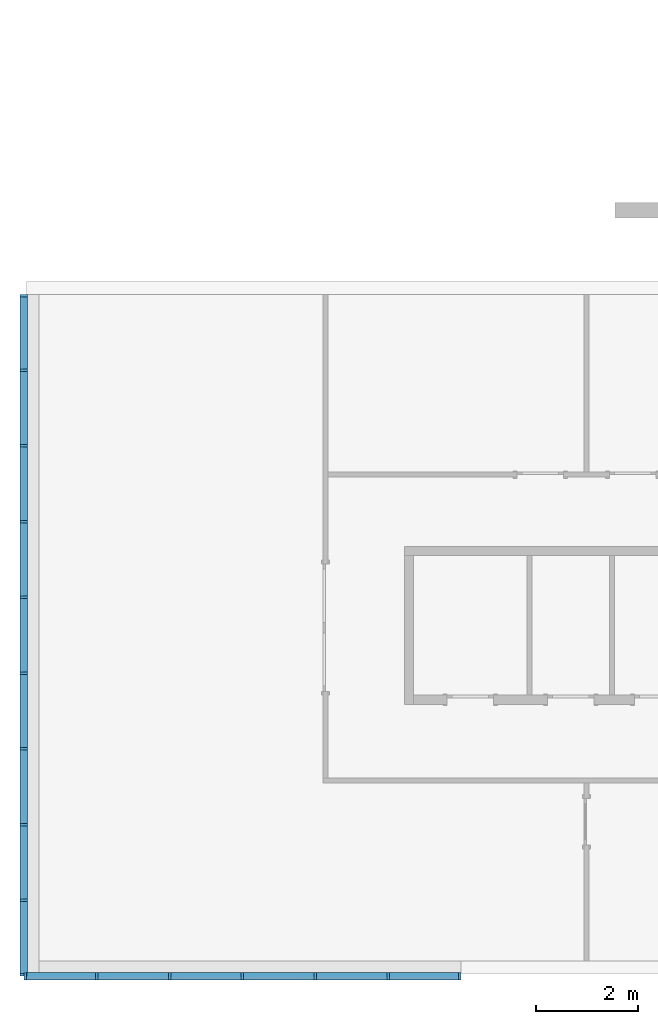
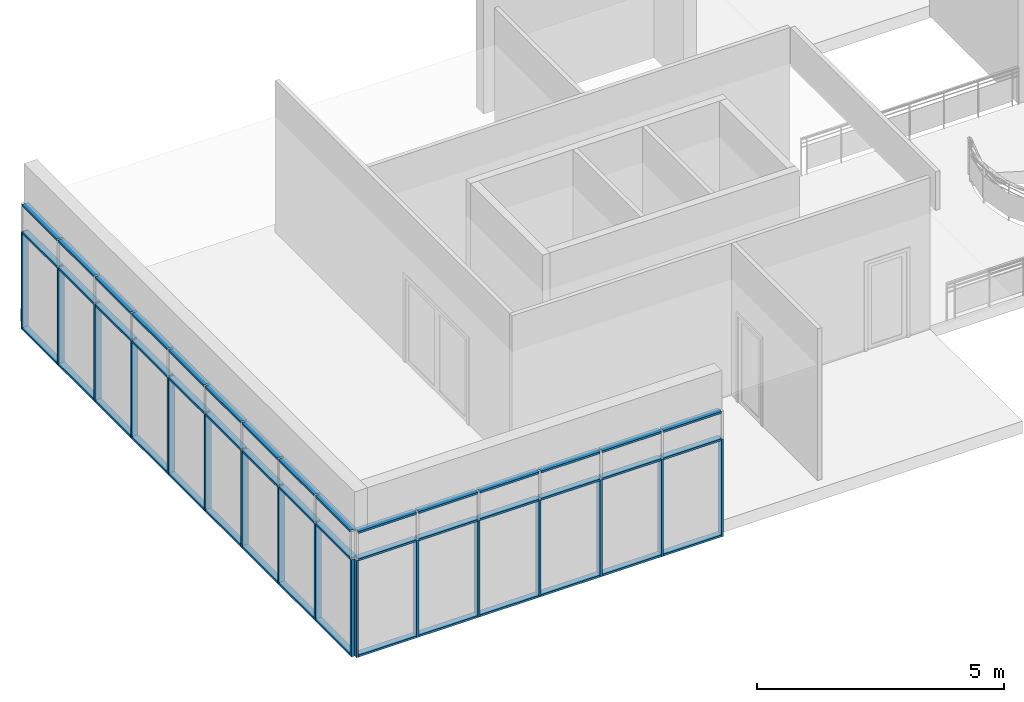
# One storey, part 1 of 11: 62 members, 2 elements without a shape of their own.
"""IFC2X3 building model written with IfcOpenShell, lengths in millimetres."""

from ifc_helpers import new_model, entity, si_unit, converted_unit, direction, frame, frame_2d, origin, origin_2d_with_axis, place, context, subcontext, project, spatial, rectangle, extrude, element, aggregate, save


model = new_model("IFC2X3")

# Units and contexts
model_context = context("Model", 3, precision=1e-06, world=origin(), true_north=direction((2.0, 6.12303176911189e-17, 1.0)))
context_of_model = context(None, 3, precision=1e-06, world=origin(), true_north=direction((2.0, 6.12303176911189e-17, 1.0)))
body_context = subcontext(model_context, "Body", "Model", "MODEL_VIEW")
ifc_project = project(units=[si_unit("LENGTHUNIT", "METRE", prefix="MILLI"), si_unit("AREAUNIT", "SQUARE_METRE", prefix="MILLI"), si_unit("VOLUMEUNIT", "CUBIC_METRE", prefix="MILLI"), converted_unit("PLANEANGLEUNIT", "DEGREE", entity("IfcRatioMeasure", 0.0174532925199433), si_unit("PLANEANGLEUNIT", "RADIAN"), dimensions=[0, 0, 0, 0, 0, 0, 0]), si_unit("TIMEUNIT", "SECOND")], contexts=[model_context, context_of_model])

# Site, building, storey
site_placement = place(None, origin())
site = spatial("IfcSite", under=ifc_project, at=site_placement, CompositionType="ELEMENT")
building_placement = place(site_placement, origin())
building = spatial("IfcBuilding", under=site, at=building_placement, CompositionType="ELEMENT")
storey_placement = place(building_placement, frame((0.0, 0.0, 3750.0)))
storey = spatial("IfcBuildingStorey", under=building, at=storey_placement, Name="02. 2 etg.", CompositionType="ELEMENT", Elevation=3750.00000000068)

# Curtain wall, members
curtain_wall_1_placement = place(storey_placement, origin())
curtain_wall_1 = element("IfcCurtainWall", 1, at=curtain_wall_1_placement, inside=storey, Name="Curtain Wall:Storefront", ObjectType="Curtain Wall:Storefront")
member_1_placement = place(storey_placement, origin())
member_1 = element("IfcMember", 2, at=member_1_placement, Name="Curtain Wall:Storefront:8486", ObjectType="Curtain Wall:Storefront:8486", context=body_context, shape_type="SweptSolid", body=[
    extrude(rectangle(XDim=1411.66666666667, YDim=150.0, at=frame_2d((1.08002495835535e-12, 0.0), x_axis=(1.0, 0.0))), frame((-240.0, -12684.1666666667, 2750.0), z_axis=(0.0, 0.0, 1.0), x_axis=(0.0, 1.0, 0.0)), (0.0, 0.0, 1.0), 49.9999999999995),
])
member_2_placement = place(storey_placement, origin())
member_2 = element("IfcMember", 3, at=member_2_placement, Name="Curtain Wall:Storefront:8486", ObjectType="Curtain Wall:Storefront:8486", context=body_context, shape_type="SweptSolid", body=[
    extrude(rectangle(XDim=1411.66666666667, YDim=150.0, at=origin_2d_with_axis()), frame((-240.0, -815.833333333277, -300.0), z_axis=(0.0, 0.0, 1.0), x_axis=(0.0, -1.0, 0.0)), (0.0, 0.0, 1.0), 50.0),
])
member_3_placement = place(storey_placement, origin())
member_3 = element("IfcMember", 4, at=member_3_placement, Name="Curtain Wall:Storefront:8486", ObjectType="Curtain Wall:Storefront:8486", context=body_context, shape_type="SweptSolid", body=[
    extrude(rectangle(XDim=150.0, YDim=49.9999999999995, at=frame_2d((2.1316282072803e-14, -1.08357767203415e-12), x_axis=(1.0, 0.0))), frame((-240.0, -13415.0, -300.0)), (0.0, 0.0, 1.0), 2400.0),
])
member_4_placement = place(storey_placement, origin())
member_4 = element("IfcMember", 5, at=member_4_placement, Name="Curtain Wall:Storefront:8486", ObjectType="Curtain Wall:Storefront:8486", context=body_context, shape_type="SweptSolid", body=[
    extrude(rectangle(XDim=1411.66666666667, YDim=150.0, at=origin_2d_with_axis()), frame((-240.0, -815.833333333278, 2750.0), z_axis=(0.0, 0.0, 1.0), x_axis=(0.0, 1.0, 0.0)), (0.0, 0.0, 1.0), 49.9999999999995),
])
member_5_placement = place(storey_placement, origin())
member_5 = element("IfcMember", 6, at=member_5_placement, Name="Curtain Wall:Storefront:8486", ObjectType="Curtain Wall:Storefront:8486", context=body_context, shape_type="SweptSolid", body=[
    extrude(rectangle(XDim=1436.66666666667, YDim=150.0, at=frame_2d((0.0, 3.5527136788005e-14), x_axis=(1.0, 0.0))), frame((-240.0, -2290.0, 2750.0), z_axis=(0.0, 0.0, 1.0), x_axis=(0.0, 1.0, 0.0)), (0.0, 0.0, 1.0), 49.9999999999995),
])
member_6_placement = place(storey_placement, origin())
member_6 = element("IfcMember", 7, at=member_6_placement, Name="Curtain Wall:Storefront:8486", ObjectType="Curtain Wall:Storefront:8486", context=body_context, shape_type="SweptSolid", body=[
    extrude(rectangle(XDim=1436.66666666667, YDim=150.0, at=frame_2d((2.8421709430404e-13, 0.0), x_axis=(1.0, 0.0))), frame((-240.0, -3776.66666666662, 2750.0), z_axis=(0.0, 0.0, 1.0), x_axis=(0.0, 1.0, 0.0)), (0.0, 0.0, 1.0), 49.9999999999995),
])
member_7_placement = place(storey_placement, origin())
member_7 = element("IfcMember", 8, at=member_7_placement, Name="Curtain Wall:Storefront:8486", ObjectType="Curtain Wall:Storefront:8486", context=body_context, shape_type="SweptSolid", body=[
    extrude(rectangle(XDim=1436.66666666667, YDim=150.0, at=frame_2d((8.5265128291212e-13, 0.0), x_axis=(1.0, 0.0))), frame((-240.0, -5263.3333333333, 2750.0), z_axis=(0.0, 0.0, 1.0), x_axis=(0.0, 1.0, 0.0)), (0.0, 0.0, 1.0), 49.9999999999995),
])
member_8_placement = place(storey_placement, origin())
member_8 = element("IfcMember", 9, at=member_8_placement, Name="Curtain Wall:Storefront:8486", ObjectType="Curtain Wall:Storefront:8486", context=body_context, shape_type="SweptSolid", body=[
    extrude(rectangle(XDim=1436.66666666667, YDim=150.0, at=frame_2d((5.6843418860808e-13, 0.0), x_axis=(1.0, 0.0))), frame((-240.0, -6750.0, 2750.0), z_axis=(0.0, 0.0, 1.0), x_axis=(0.0, 1.0, 0.0)), (0.0, 0.0, 1.0), 49.9999999999995),
])
member_9_placement = place(storey_placement, origin())
member_9 = element("IfcMember", 10, at=member_9_placement, Name="Curtain Wall:Storefront:8486", ObjectType="Curtain Wall:Storefront:8486", context=body_context, shape_type="SweptSolid", body=[
    extrude(rectangle(XDim=1436.66666666667, YDim=150.0, at=frame_2d((-5.6843418860808e-13, -3.5527136788005e-14), x_axis=(1.0, 0.0))), frame((-240.0, -8236.66666666664, 2750.0), z_axis=(0.0, 0.0, 1.0), x_axis=(0.0, 1.0, 0.0)), (0.0, 0.0, 1.0), 49.9999999999995),
])
member_10_placement = place(storey_placement, origin())
member_10 = element("IfcMember", 11, at=member_10_placement, Name="Curtain Wall:Storefront:8486", ObjectType="Curtain Wall:Storefront:8486", context=body_context, shape_type="SweptSolid", body=[
    extrude(rectangle(XDim=1436.66666666667, YDim=150.0, at=origin_2d_with_axis()), frame((-240.0, -9723.33333333331, 2750.0), z_axis=(0.0, 0.0, 1.0), x_axis=(0.0, 1.0, 0.0)), (0.0, 0.0, 1.0), 49.9999999999995),
])
member_11_placement = place(storey_placement, origin())
member_11 = element("IfcMember", 12, at=member_11_placement, Name="Curtain Wall:Storefront:8486", ObjectType="Curtain Wall:Storefront:8486", context=body_context, shape_type="SweptSolid", body=[
    extrude(rectangle(XDim=1436.66666666667, YDim=150.0, at=origin_2d_with_axis()), frame((-240.0, -11210.0, 2750.0), z_axis=(0.0, 0.0, 1.0), x_axis=(0.0, 1.0, 0.0)), (0.0, 0.0, 1.0), 49.9999999999995),
])
member_12_placement = place(storey_placement, origin())
member_12 = element("IfcMember", 13, at=member_12_placement, Name="Curtain Wall:Storefront:8486", ObjectType="Curtain Wall:Storefront:8486", context=body_context, shape_type="SweptSolid", body=[
    extrude(rectangle(XDim=1436.66666666667, YDim=150.0, at=frame_2d((-1.70530256582424e-13, -1.4210854715202e-14), x_axis=(1.0, 0.0))), frame((-240.0, -2290.0, -300.0), z_axis=(0.0, 0.0, 1.0), x_axis=(0.0, -1.0, 0.0)), (0.0, 0.0, 1.0), 50.0),
])
member_13_placement = place(storey_placement, origin())
member_13 = element("IfcMember", 14, at=member_13_placement, Name="Curtain Wall:Storefront:8486", ObjectType="Curtain Wall:Storefront:8486", context=body_context, shape_type="SweptSolid", body=[
    extrude(rectangle(XDim=1436.66666666667, YDim=150.0, at=frame_2d((-2.8421709430404e-13, 1.4210854715202e-14), x_axis=(1.0, 0.0))), frame((-240.0, -3776.66666666662, -300.0), z_axis=(0.0, 0.0, 1.0), x_axis=(0.0, -1.0, 0.0)), (0.0, 0.0, 1.0), 50.0),
])
member_14_placement = place(storey_placement, origin())
member_14 = element("IfcMember", 15, at=member_14_placement, Name="Curtain Wall:Storefront:8486", ObjectType="Curtain Wall:Storefront:8486", context=body_context, shape_type="SweptSolid", body=[
    extrude(rectangle(XDim=1436.66666666667, YDim=150.0, at=frame_2d((5.6843418860808e-13, -1.4210854715202e-14), x_axis=(1.0, 0.0))), frame((-240.0, -5263.3333333333, -300.0), z_axis=(0.0, 0.0, 1.0), x_axis=(0.0, -1.0, 0.0)), (0.0, 0.0, 1.0), 50.0),
])
member_15_placement = place(storey_placement, origin())
member_15 = element("IfcMember", 16, at=member_15_placement, Name="Curtain Wall:Storefront:8486", ObjectType="Curtain Wall:Storefront:8486", context=body_context, shape_type="SweptSolid", body=[
    extrude(rectangle(XDim=1436.66666666667, YDim=150.0, at=frame_2d((-5.6843418860808e-13, -1.4210854715202e-14), x_axis=(1.0, 0.0))), frame((-240.0, -6750.0, -300.0), z_axis=(0.0, 0.0, 1.0), x_axis=(0.0, -1.0, 0.0)), (0.0, 0.0, 1.0), 50.0),
])
member_16_placement = place(storey_placement, origin())
member_16 = element("IfcMember", 17, at=member_16_placement, Name="Curtain Wall:Storefront:8486", ObjectType="Curtain Wall:Storefront:8486", context=body_context, shape_type="SweptSolid", body=[
    extrude(rectangle(XDim=1436.66666666667, YDim=150.0, at=frame_2d((5.6843418860808e-13, -1.4210854715202e-14), x_axis=(1.0, 0.0))), frame((-240.0, -8236.66666666664, -300.0), z_axis=(0.0, 0.0, 1.0), x_axis=(0.0, -1.0, 0.0)), (0.0, 0.0, 1.0), 50.0),
])
member_17_placement = place(storey_placement, origin())
member_17 = element("IfcMember", 18, at=member_17_placement, Name="Curtain Wall:Storefront:8486", ObjectType="Curtain Wall:Storefront:8486", context=body_context, shape_type="SweptSolid", body=[
    extrude(rectangle(XDim=1436.66666666667, YDim=150.0, at=frame_2d((5.6843418860808e-13, 1.4210854715202e-14), x_axis=(1.0, 0.0))), frame((-240.0, -9723.33333333331, -300.0), z_axis=(0.0, 0.0, 1.0), x_axis=(0.0, -1.0, 0.0)), (0.0, 0.0, 1.0), 50.0),
])
member_18_placement = place(storey_placement, origin())
member_18 = element("IfcMember", 19, at=member_18_placement, Name="Curtain Wall:Storefront:8486", ObjectType="Curtain Wall:Storefront:8486", context=body_context, shape_type="SweptSolid", body=[
    extrude(rectangle(XDim=1436.66666666667, YDim=150.0, at=frame_2d((0.0, -1.4210854715202e-14), x_axis=(1.0, 0.0))), frame((-240.0, -11210.0, -300.0), z_axis=(0.0, 0.0, 1.0), x_axis=(0.0, -1.0, 0.0)), (0.0, 0.0, 1.0), 50.0),
])
member_19_placement = place(storey_placement, origin())
member_19 = element("IfcMember", 20, at=member_19_placement, Name="Curtain Wall:Storefront:8486", ObjectType="Curtain Wall:Storefront:8486", context=body_context, shape_type="SweptSolid", body=[
    extrude(rectangle(XDim=1411.66666666667, YDim=150.0, at=frame_2d((-1.08002495835535e-12, 1.4210854715202e-14), x_axis=(1.0, 0.0))), frame((-240.0, -12684.1666666667, -300.0), z_axis=(0.0, 0.0, 1.0), x_axis=(0.0, -1.0, 0.0)), (0.0, 0.0, 1.0), 50.0),
])
member_20_placement = place(storey_placement, origin())
member_20 = element("IfcMember", 21, at=member_20_placement, Name="Curtain Wall:Storefront:8486", ObjectType="Curtain Wall:Storefront:8486", context=body_context, shape_type="SweptSolid", body=[
    extrude(rectangle(XDim=50.0, YDim=150.0, at=frame_2d((1.24344978758018e-14, 1.4210854715202e-14), x_axis=(1.0, 0.0))), frame((-240.0, -85.0, -300.0), z_axis=(0.0, 0.0, 1.0), x_axis=(0.0, -1.0, 0.0)), (0.0, 0.0, 1.0), 2400.0),
])
member_21_placement = place(storey_placement, origin())
member_21 = element("IfcMember", 22, at=member_21_placement, Name="Curtain Wall:Storefront:8486", ObjectType="Curtain Wall:Storefront:8486", context=body_context, shape_type="SweptSolid", body=[
    extrude(rectangle(XDim=1411.66666666667, YDim=150.0, at=frame_2d((0.0, -2.8421709430404e-14), x_axis=(1.0, 0.0))), frame((-240.0, -815.833333333277, 2075.0), z_axis=(0.0, 0.0, 1.0), x_axis=(0.0, 1.0, 0.0)), (0.0, 0.0, 1.0), 49.9999999999995),
])
member_22_placement = place(storey_placement, origin())
member_22 = element("IfcMember", 23, at=member_22_placement, Name="Curtain Wall:Storefront:8486", ObjectType="Curtain Wall:Storefront:8486", context=body_context, shape_type="SweptSolid", body=[
    extrude(rectangle(XDim=1436.66666666667, YDim=150.0, at=frame_2d((0.0, 3.5527136788005e-14), x_axis=(1.0, 0.0))), frame((-240.0, -2290.0, 2075.0), z_axis=(0.0, 0.0, 1.0), x_axis=(0.0, 1.0, 0.0)), (0.0, 0.0, 1.0), 49.9999999999995),
])
member_23_placement = place(storey_placement, origin())
member_23 = element("IfcMember", 24, at=member_23_placement, Name="Curtain Wall:Storefront:8486", ObjectType="Curtain Wall:Storefront:8486", context=body_context, shape_type="SweptSolid", body=[
    extrude(rectangle(XDim=1436.66666666667, YDim=150.0, at=frame_2d((-2.8421709430404e-13, 0.0), x_axis=(1.0, 0.0))), frame((-240.0, -3776.66666666662, 2075.0), z_axis=(0.0, 0.0, 1.0), x_axis=(0.0, 1.0, 0.0)), (0.0, 0.0, 1.0), 49.9999999999995),
])
member_24_placement = place(storey_placement, origin())
member_24 = element("IfcMember", 25, at=member_24_placement, Name="Curtain Wall:Storefront:8486", ObjectType="Curtain Wall:Storefront:8486", context=body_context, shape_type="SweptSolid", body=[
    extrude(rectangle(XDim=1436.66666666667, YDim=150.0, at=frame_2d((-2.8421709430404e-13, 3.5527136788005e-14), x_axis=(1.0, 0.0))), frame((-240.0, -5263.3333333333, 2075.0), z_axis=(0.0, 0.0, 1.0), x_axis=(0.0, 1.0, 0.0)), (0.0, 0.0, 1.0), 49.9999999999995),
])
member_25_placement = place(storey_placement, origin())
member_25 = element("IfcMember", 26, at=member_25_placement, Name="Curtain Wall:Storefront:8486", ObjectType="Curtain Wall:Storefront:8486", context=body_context, shape_type="SweptSolid", body=[
    extrude(rectangle(XDim=1436.66666666667, YDim=150.0, at=frame_2d((5.6843418860808e-13, 0.0), x_axis=(1.0, 0.0))), frame((-240.0, -6750.0, 2075.0), z_axis=(0.0, 0.0, 1.0), x_axis=(0.0, 1.0, 0.0)), (0.0, 0.0, 1.0), 49.9999999999995),
])
member_26_placement = place(storey_placement, origin())
member_26 = element("IfcMember", 27, at=member_26_placement, Name="Curtain Wall:Storefront:8486", ObjectType="Curtain Wall:Storefront:8486", context=body_context, shape_type="SweptSolid", body=[
    extrude(rectangle(XDim=1436.66666666667, YDim=150.0, at=frame_2d((-5.6843418860808e-13, 0.0), x_axis=(1.0, 0.0))), frame((-240.0, -8236.66666666664, 2075.0), z_axis=(0.0, 0.0, 1.0), x_axis=(0.0, 1.0, 0.0)), (0.0, 0.0, 1.0), 49.9999999999995),
])
member_27_placement = place(storey_placement, origin())
member_27 = element("IfcMember", 28, at=member_27_placement, Name="Curtain Wall:Storefront:8486", ObjectType="Curtain Wall:Storefront:8486", context=body_context, shape_type="SweptSolid", body=[
    extrude(rectangle(XDim=1436.66666666667, YDim=150.0, at=origin_2d_with_axis()), frame((-240.0, -9723.33333333331, 2075.0), z_axis=(0.0, 0.0, 1.0), x_axis=(0.0, 1.0, 0.0)), (0.0, 0.0, 1.0), 49.9999999999995),
])
member_28_placement = place(storey_placement, origin())
member_28 = element("IfcMember", 29, at=member_28_placement, Name="Curtain Wall:Storefront:8486", ObjectType="Curtain Wall:Storefront:8486", context=body_context, shape_type="SweptSolid", body=[
    extrude(rectangle(XDim=1436.66666666667, YDim=150.0, at=origin_2d_with_axis()), frame((-240.0, -11210.0, 2075.0), z_axis=(0.0, 0.0, 1.0), x_axis=(0.0, 1.0, 0.0)), (0.0, 0.0, 1.0), 49.9999999999995),
])
member_29_placement = place(storey_placement, origin())
member_29 = element("IfcMember", 30, at=member_29_placement, Name="Curtain Wall:Storefront:8486", ObjectType="Curtain Wall:Storefront:8486", context=body_context, shape_type="SweptSolid", body=[
    extrude(rectangle(XDim=1411.66666666667, YDim=150.0, at=frame_2d((1.08002495835535e-12, 0.0), x_axis=(1.0, 0.0))), frame((-240.0, -12684.1666666667, 2075.0), z_axis=(0.0, 0.0, 1.0), x_axis=(0.0, 1.0, 0.0)), (0.0, 0.0, 1.0), 49.9999999999995),
])
member_30_placement = place(storey_placement, origin())
member_30 = element("IfcMember", 31, at=member_30_placement, Name="Curtain Wall:Storefront:8486", ObjectType="Curtain Wall:Storefront:8486", context=body_context, shape_type="SweptSolid", body=[
    extrude(rectangle(XDim=150.0, YDim=50.0, at=frame_2d((3.5527136788005e-14, -1.36779476633819e-13), x_axis=(1.0, 0.0))), frame((-240.0, -1546.66666666661, -300.0)), (0.0, 0.0, 1.0), 2400.0),
])
member_31_placement = place(storey_placement, origin())
member_31 = element("IfcMember", 32, at=member_31_placement, Name="Curtain Wall:Storefront:8486", ObjectType="Curtain Wall:Storefront:8486", context=body_context, shape_type="SweptSolid", body=[
    extrude(rectangle(XDim=150.0, YDim=50.0, at=frame_2d((2.1316282072803e-14, -2.71782596428238e-13), x_axis=(1.0, 0.0))), frame((-240.0, -3033.33333333329, -300.0)), (0.0, 0.0, 1.0), 2400.0),
])
member_32_placement = place(storey_placement, origin())
member_32 = element("IfcMember", 33, at=member_32_placement, Name="Curtain Wall:Storefront:8486", ObjectType="Curtain Wall:Storefront:8486", context=body_context, shape_type="SweptSolid", body=[
    extrude(rectangle(XDim=150.0, YDim=50.0, at=frame_2d((-3.5527136788005e-14, 2.71782596428238e-13), x_axis=(1.0, 0.0))), frame((-240.0, -4520.0, -300.0)), (0.0, 0.0, 1.0), 2400.0),
])
member_33_placement = place(storey_placement, origin())
member_33 = element("IfcMember", 34, at=member_33_placement, Name="Curtain Wall:Storefront:8486", ObjectType="Curtain Wall:Storefront:8486", context=body_context, shape_type="SweptSolid", body=[
    extrude(rectangle(XDim=150.0, YDim=50.0000000000005, at=frame_2d((2.1316282072803e-14, 0.0), x_axis=(1.0, 0.0))), frame((-240.0, -6006.66666666663, -300.0)), (0.0, 0.0, 1.0), 2400.0),
])
member_34_placement = place(storey_placement, origin())
member_34 = element("IfcMember", 35, at=member_34_placement, Name="Curtain Wall:Storefront:8486", ObjectType="Curtain Wall:Storefront:8486", context=body_context, shape_type="SweptSolid", body=[
    extrude(rectangle(XDim=150.0, YDim=50.0000000000005, at=frame_2d((3.5527136788005e-14, 0.0), x_axis=(1.0, 0.0))), frame((-240.0, -7493.33333333331, -300.0)), (0.0, 0.0, 1.0), 2400.0),
])
member_35_placement = place(storey_placement, origin())
member_35 = element("IfcMember", 36, at=member_35_placement, Name="Curtain Wall:Storefront:8486", ObjectType="Curtain Wall:Storefront:8486", context=body_context, shape_type="SweptSolid", body=[
    extrude(rectangle(XDim=150.0, YDim=50.0000000000005, at=frame_2d((2.1316282072803e-14, 0.0), x_axis=(1.0, 0.0))), frame((-240.0, -8980.0, -300.0)), (0.0, 0.0, 1.0), 2400.0),
])
member_36_placement = place(storey_placement, origin())
member_36 = element("IfcMember", 37, at=member_36_placement, Name="Curtain Wall:Storefront:8486", ObjectType="Curtain Wall:Storefront:8486", context=body_context, shape_type="SweptSolid", body=[
    extrude(rectangle(XDim=150.0, YDim=49.9999999999995, at=frame_2d((0.0, -1.08357767203415e-12), x_axis=(1.0, 0.0))), frame((-240.0, -10466.6666666667, -300.0)), (0.0, 0.0, 1.0), 2400.0),
])
member_37_placement = place(storey_placement, origin())
member_37 = element("IfcMember", 38, at=member_37_placement, Name="Curtain Wall:Storefront:8486", ObjectType="Curtain Wall:Storefront:8486", context=body_context, shape_type="SweptSolid", body=[
    extrude(rectangle(XDim=150.0, YDim=49.9999999999995, at=frame_2d((1.4210854715202e-14, 1.08357767203415e-12), x_axis=(1.0, 0.0))), frame((-240.0, -11953.3333333333, -300.0)), (0.0, 0.0, 1.0), 2400.0),
])
aggregate(curtain_wall_1, [member_1, member_2, member_3, member_4, member_5, member_6, member_7, member_8, member_9, member_10, member_11, member_12, member_13, member_14, member_15, member_16, member_17, member_18, member_19, member_20, member_21, member_22, member_23, member_24, member_25, member_26, member_27, member_28, member_29, member_30, member_31, member_32, member_33, member_34, member_35, member_36, member_37])

curtain_wall_2_placement = place(storey_placement, origin())
curtain_wall_2 = element("IfcCurtainWall", 39, at=curtain_wall_2_placement, inside=storey, Name="Curtain Wall:Storefront", ObjectType="Curtain Wall:Storefront")
member_38_placement = place(storey_placement, origin())
member_38 = element("IfcMember", 40, at=member_38_placement, Name="Curtain Wall:Storefront:8486", ObjectType="Curtain Wall:Storefront:8486", context=body_context, shape_type="SweptSolid", body=[
    extrude(rectangle(XDim=1355.0, YDim=150.000000000001, at=origin_2d_with_axis()), frame((7612.5, -13440.0, 2750.0), z_axis=(0.0, 0.0, 1.0), x_axis=(-1.0, 0.0, 0.0)), (0.0, 0.0, 1.0), 49.9999999999995),
])
member_39_placement = place(storey_placement, origin())
member_39 = element("IfcMember", 41, at=member_39_placement, Name="Curtain Wall:Storefront:8486", ObjectType="Curtain Wall:Storefront:8486", context=body_context, shape_type="SweptSolid", body=[
    extrude(rectangle(XDim=1355.0, YDim=150.000000000001, at=frame_2d((0.0, -2.16715534406831e-12), x_axis=(1.0, 0.0))), frame((487.49999999998, -13440.0, -300.0)), (0.0, 0.0, 1.0), 50.0),
])
member_40_placement = place(storey_placement, origin())
member_40 = element("IfcMember", 42, at=member_40_placement, Name="Curtain Wall:Storefront:8486", ObjectType="Curtain Wall:Storefront:8486", context=body_context, shape_type="SweptSolid", body=[
    extrude(rectangle(XDim=150.000000000001, YDim=50.0000000000005, at=frame_2d((0.0, 5.41788836017076e-13), x_axis=(1.0, 0.0))), frame((8315.0, -13440.0, -300.0), z_axis=(0.0, 0.0, 1.0), x_axis=(0.0, 1.0, 0.0)), (0.0, 0.0, 1.0), 2400.0),
])
member_41_placement = place(storey_placement, origin())
member_41 = element("IfcMember", 43, at=member_41_placement, Name="Curtain Wall:Storefront:8486", ObjectType="Curtain Wall:Storefront:8486", context=body_context, shape_type="SweptSolid", body=[
    extrude(rectangle(XDim=1355.0, YDim=150.000000000001, at=origin_2d_with_axis()), frame((487.49999999998, -13440.0, 2750.0), z_axis=(0.0, 0.0, 1.0), x_axis=(-1.0, 0.0, 0.0)), (0.0, 0.0, 1.0), 49.9999999999995),
])
member_42_placement = place(storey_placement, origin())
member_42 = element("IfcMember", 44, at=member_42_placement, Name="Curtain Wall:Storefront:8486", ObjectType="Curtain Wall:Storefront:8486", context=body_context, shape_type="SweptSolid", body=[
    extrude(rectangle(XDim=1380.0, YDim=150.000000000001, at=frame_2d((0.0, -2.16715534406831e-12), x_axis=(1.0, 0.0))), frame((1905.0, -13440.0, 2750.0), z_axis=(0.0, 0.0, 1.0), x_axis=(-1.0, 0.0, 0.0)), (0.0, 0.0, 1.0), 49.9999999999995),
])
member_43_placement = place(storey_placement, origin())
member_43 = element("IfcMember", 45, at=member_43_placement, Name="Curtain Wall:Storefront:8486", ObjectType="Curtain Wall:Storefront:8486", context=body_context, shape_type="SweptSolid", body=[
    extrude(rectangle(XDim=1380.0, YDim=150.000000000001, at=frame_2d((2.8421709430404e-13, 0.0), x_axis=(1.0, 0.0))), frame((3335.0, -13440.0, 2750.0), z_axis=(0.0, 0.0, 1.0), x_axis=(-1.0, 0.0, 0.0)), (0.0, 0.0, 1.0), 49.9999999999995),
])
member_44_placement = place(storey_placement, origin())
member_44 = element("IfcMember", 46, at=member_44_placement, Name="Curtain Wall:Storefront:8486", ObjectType="Curtain Wall:Storefront:8486", context=body_context, shape_type="SweptSolid", body=[
    extrude(rectangle(XDim=1380.0, YDim=150.000000000001, at=frame_2d((-5.6843418860808e-13, -1.08713038571295e-12), x_axis=(1.0, 0.0))), frame((4765.0, -13440.0, 2750.0), z_axis=(0.0, 0.0, 1.0), x_axis=(-1.0, 0.0, 0.0)), (0.0, 0.0, 1.0), 49.9999999999995),
])
member_45_placement = place(storey_placement, origin())
member_45 = element("IfcMember", 47, at=member_45_placement, Name="Curtain Wall:Storefront:8486", ObjectType="Curtain Wall:Storefront:8486", context=body_context, shape_type="SweptSolid", body=[
    extrude(rectangle(XDim=1380.0, YDim=150.000000000001, at=frame_2d((5.6843418860808e-13, 0.0), x_axis=(1.0, 0.0))), frame((6195.0, -13440.0, 2750.0), z_axis=(0.0, 0.0, 1.0), x_axis=(-1.0, 0.0, 0.0)), (0.0, 0.0, 1.0), 49.9999999999995),
])
member_46_placement = place(storey_placement, origin())
member_46 = element("IfcMember", 48, at=member_46_placement, Name="Curtain Wall:Storefront:8486", ObjectType="Curtain Wall:Storefront:8486", context=body_context, shape_type="SweptSolid", body=[
    extrude(rectangle(XDim=1380.0, YDim=150.000000000001, at=frame_2d((-1.13686837721616e-13, 0.0), x_axis=(1.0, 0.0))), frame((1905.0, -13440.0, -300.0)), (0.0, 0.0, 1.0), 50.0),
])
member_47_placement = place(storey_placement, origin())
member_47 = element("IfcMember", 49, at=member_47_placement, Name="Curtain Wall:Storefront:8486", ObjectType="Curtain Wall:Storefront:8486", context=body_context, shape_type="SweptSolid", body=[
    extrude(rectangle(XDim=1380.0, YDim=150.000000000001, at=frame_2d((0.0, 2.16715534406831e-12), x_axis=(1.0, 0.0))), frame((3335.0, -13440.0, -300.0)), (0.0, 0.0, 1.0), 50.0),
])
member_48_placement = place(storey_placement, origin())
member_48 = element("IfcMember", 50, at=member_48_placement, Name="Curtain Wall:Storefront:8486", ObjectType="Curtain Wall:Storefront:8486", context=body_context, shape_type="SweptSolid", body=[
    extrude(rectangle(XDim=1380.0, YDim=150.000000000001, at=frame_2d((5.6843418860808e-13, 1.08713038571295e-12), x_axis=(1.0, 0.0))), frame((4765.0, -13440.0, -300.0)), (0.0, 0.0, 1.0), 50.0),
])
member_49_placement = place(storey_placement, origin())
member_49 = element("IfcMember", 51, at=member_49_placement, Name="Curtain Wall:Storefront:8486", ObjectType="Curtain Wall:Storefront:8486", context=body_context, shape_type="SweptSolid", body=[
    extrude(rectangle(XDim=1380.0, YDim=150.000000000001, at=frame_2d((-5.6843418860808e-13, 0.0), x_axis=(1.0, 0.0))), frame((6195.0, -13440.0, -300.0)), (0.0, 0.0, 1.0), 50.0),
])
member_50_placement = place(storey_placement, origin())
member_50 = element("IfcMember", 52, at=member_50_placement, Name="Curtain Wall:Storefront:8486", ObjectType="Curtain Wall:Storefront:8486", context=body_context, shape_type="SweptSolid", body=[
    extrude(rectangle(XDim=1355.0, YDim=150.000000000001, at=origin_2d_with_axis()), frame((7612.5, -13440.0, -300.0)), (0.0, 0.0, 1.0), 50.0),
])
member_51_placement = place(storey_placement, origin())
member_51 = element("IfcMember", 53, at=member_51_placement, Name="Curtain Wall:Storefront:8486", ObjectType="Curtain Wall:Storefront:8486", context=body_context, shape_type="SweptSolid", body=[
    extrude(rectangle(XDim=50.0, YDim=150.000000000001, at=frame_2d((3.37507799486048e-14, -1.08002495835535e-12), x_axis=(1.0, 0.0))), frame((-215.0, -13440.0, -300.0)), (0.0, 0.0, 1.0), 2400.0),
])
member_52_placement = place(storey_placement, origin())
member_52 = element("IfcMember", 54, at=member_52_placement, Name="Curtain Wall:Storefront:8486", ObjectType="Curtain Wall:Storefront:8486", context=body_context, shape_type="SweptSolid", body=[
    extrude(rectangle(XDim=1355.0, YDim=150.000000000001, at=origin_2d_with_axis()), frame((487.49999999998, -13440.0, 2075.0), z_axis=(0.0, 0.0, 1.0), x_axis=(-1.0, 0.0, 0.0)), (0.0, 0.0, 1.0), 49.9999999999995),
])
member_53_placement = place(storey_placement, origin())
member_53 = element("IfcMember", 55, at=member_53_placement, Name="Curtain Wall:Storefront:8486", ObjectType="Curtain Wall:Storefront:8486", context=body_context, shape_type="SweptSolid", body=[
    extrude(rectangle(XDim=1380.0, YDim=150.000000000001, at=frame_2d((0.0, -2.16715534406831e-12), x_axis=(1.0, 0.0))), frame((1905.0, -13440.0, 2075.0), z_axis=(0.0, 0.0, 1.0), x_axis=(-1.0, 0.0, 0.0)), (0.0, 0.0, 1.0), 49.9999999999995),
])
member_54_placement = place(storey_placement, origin())
member_54 = element("IfcMember", 56, at=member_54_placement, Name="Curtain Wall:Storefront:8486", ObjectType="Curtain Wall:Storefront:8486", context=body_context, shape_type="SweptSolid", body=[
    extrude(rectangle(XDim=1380.0, YDim=150.000000000001, at=origin_2d_with_axis()), frame((3335.0, -13440.0, 2075.0), z_axis=(0.0, 0.0, 1.0), x_axis=(-1.0, 0.0, 0.0)), (0.0, 0.0, 1.0), 49.9999999999995),
])
member_55_placement = place(storey_placement, origin())
member_55 = element("IfcMember", 57, at=member_55_placement, Name="Curtain Wall:Storefront:8486", ObjectType="Curtain Wall:Storefront:8486", context=body_context, shape_type="SweptSolid", body=[
    extrude(rectangle(XDim=1380.0, YDim=149.999999999998, at=origin_2d_with_axis()), frame((4765.0, -13440.0, 2075.0), z_axis=(0.0, 0.0, 1.0), x_axis=(-1.0, 0.0, 0.0)), (0.0, 0.0, 1.0), 49.9999999999995),
])
member_56_placement = place(storey_placement, origin())
member_56 = element("IfcMember", 58, at=member_56_placement, Name="Curtain Wall:Storefront:8486", ObjectType="Curtain Wall:Storefront:8486", context=body_context, shape_type="SweptSolid", body=[
    extrude(rectangle(XDim=1380.0, YDim=149.999999999998, at=frame_2d((-5.6843418860808e-13, 1.08002495835535e-12), x_axis=(1.0, 0.0))), frame((6195.0, -13440.0, 2075.0), z_axis=(0.0, 0.0, 1.0), x_axis=(-1.0, 0.0, 0.0)), (0.0, 0.0, 1.0), 49.9999999999995),
])
member_57_placement = place(storey_placement, origin())
member_57 = element("IfcMember", 59, at=member_57_placement, Name="Curtain Wall:Storefront:8486", ObjectType="Curtain Wall:Storefront:8486", context=body_context, shape_type="SweptSolid", body=[
    extrude(rectangle(XDim=1355.0, YDim=149.999999999998, at=frame_2d((0.0, -1.08002495835535e-12), x_axis=(1.0, 0.0))), frame((7612.5, -13440.0, 2075.0), z_axis=(0.0, 0.0, 1.0), x_axis=(-1.0, 0.0, 0.0)), (0.0, 0.0, 1.0), 49.9999999999995),
])
member_58_placement = place(storey_placement, origin())
member_58 = element("IfcMember", 60, at=member_58_placement, Name="Curtain Wall:Storefront:8486", ObjectType="Curtain Wall:Storefront:8486", context=body_context, shape_type="SweptSolid", body=[
    extrude(rectangle(XDim=149.999999999998, YDim=50.0, at=origin_2d_with_axis()), frame((1190.0, -13440.0, -300.0), z_axis=(0.0, 0.0, 1.0), x_axis=(0.0, 1.0, 0.0)), (0.0, 0.0, 1.0), 2400.0),
])
member_59_placement = place(storey_placement, origin())
member_59 = element("IfcMember", 61, at=member_59_placement, Name="Curtain Wall:Storefront:8486", ObjectType="Curtain Wall:Storefront:8486", context=body_context, shape_type="SweptSolid", body=[
    extrude(rectangle(XDim=149.999999999998, YDim=50.0, at=frame_2d((0.0, 5.41788836017076e-13), x_axis=(1.0, 0.0))), frame((2620.0, -13440.0, -300.0), z_axis=(0.0, 0.0, 1.0), x_axis=(0.0, 1.0, 0.0)), (0.0, 0.0, 1.0), 2400.0),
])
member_60_placement = place(storey_placement, origin())
member_60 = element("IfcMember", 62, at=member_60_placement, Name="Curtain Wall:Storefront:8486", ObjectType="Curtain Wall:Storefront:8486", context=body_context, shape_type="SweptSolid", body=[
    extrude(rectangle(XDim=149.999999999998, YDim=50.0, at=frame_2d((0.0, -5.41788836017076e-13), x_axis=(1.0, 0.0))), frame((4050.0, -13440.0, -300.0), z_axis=(0.0, 0.0, 1.0), x_axis=(0.0, 1.0, 0.0)), (0.0, 0.0, 1.0), 2400.0),
])
member_61_placement = place(storey_placement, origin())
member_61 = element("IfcMember", 63, at=member_61_placement, Name="Curtain Wall:Storefront:8486", ObjectType="Curtain Wall:Storefront:8486", context=body_context, shape_type="SweptSolid", body=[
    extrude(rectangle(XDim=149.999999999998, YDim=50.0000000000005, at=frame_2d((2.16715534406831e-12, 0.0), x_axis=(1.0, 0.0))), frame((5480.0, -13440.0, -300.0), z_axis=(0.0, 0.0, 1.0), x_axis=(0.0, 1.0, 0.0)), (0.0, 0.0, 1.0), 2400.0),
])
member_62_placement = place(storey_placement, origin())
member_62 = element("IfcMember", 64, at=member_62_placement, Name="Curtain Wall:Storefront:8486", ObjectType="Curtain Wall:Storefront:8486", context=body_context, shape_type="SweptSolid", body=[
    extrude(rectangle(XDim=149.999999999998, YDim=50.0000000000005, at=origin_2d_with_axis()), frame((6910.0, -13440.0, -300.0), z_axis=(0.0, 0.0, 1.0), x_axis=(0.0, 1.0, 0.0)), (0.0, 0.0, 1.0), 2400.0),
])
aggregate(curtain_wall_2, [member_38, member_39, member_40, member_41, member_42, member_43, member_44, member_45, member_46, member_47, member_48, member_49, member_50, member_51, member_52, member_53, member_54, member_55, member_56, member_57, member_58, member_59, member_60, member_61, member_62])

save(model, "model.ifc")
